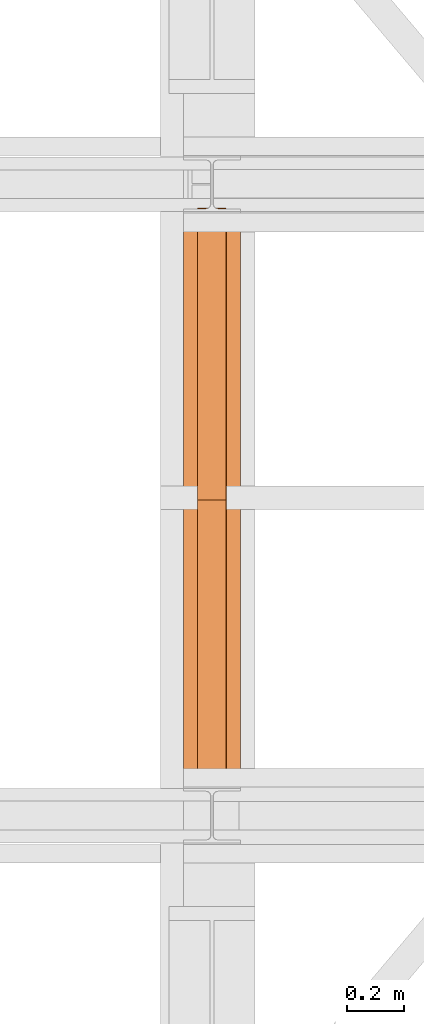
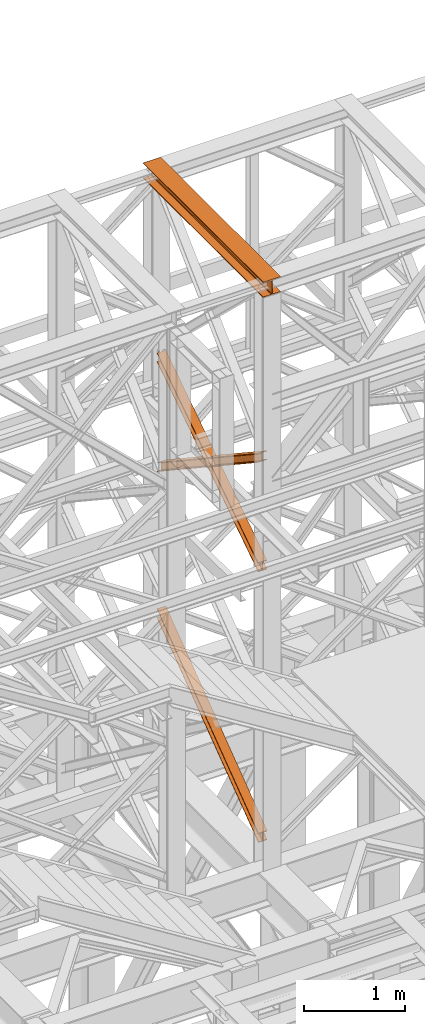
# One storey, part 115 of 208: 4 proxies.
"""IFC2X3 building model written with IfcOpenShell, lengths in millimetres."""

from ifc_helpers import new_model, entity, si_unit, converted_unit, frame, origin, origin_with_axes, place, context, subcontext, project, spatial, faceted_brep, element, save


model = new_model("IFC2X3")

# Units and contexts
model_context = context("Model", 3, precision=1e-05, world=origin())
plan_context = context("Plan", 3, precision=1e-05, world=origin())
body_context = subcontext(model_context, "Body", "Model", "MODEL_VIEW")
ifc_project = project(units=[si_unit("LENGTHUNIT", "METRE", prefix="MILLI"), converted_unit("PLANEANGLEUNIT", "DEGREE", entity("IfcPlaneAngleMeasure", 0.0174532925199433), si_unit("PLANEANGLEUNIT", "RADIAN"), dimensions=[0, 0, 0, 0, 0, 0, 0]), si_unit("AREAUNIT", "SQUARE_METRE"), si_unit("VOLUMEUNIT", "CUBIC_METRE")], contexts=[model_context, plan_context])

# Building, storey
building_placement = place(None, origin())
building = spatial("IfcBuilding", under=ifc_project, at=building_placement, CompositionType="COMPLEX")
storey_placement = place(building_placement, origin_with_axes())
storey = spatial("IfcBuildingStorey", under=building, at=storey_placement, Name="Geschoss", CompositionType="ELEMENT")

# Proxies
proxy_1_placement = place(storey_placement, frame((-106.745032961451, -16057.57439657637, 12249.99005869381), z_axis=(0.0, 0.0, 1.0), x_axis=(1.0, 0.0, 0.0)))
element("IfcBuildingElementProxy", 1, at=proxy_1_placement, inside=storey, context=body_context, shape_type="Brep", body=[
    faceted_brep([(0.01000000000000512, 2390.010012516976, 0.01000000000021828), (200.0100029802322, 2390.010012516976, 0.01000000000021828), (200.0100029802322, 2390.010012516976, 10.00999791383765), (121.2600035762787, 2390.010012516976, 10.01000536441825), (111.9441915473342, 2390.010012516976, 11.87455041170142), (105.1245498640835, 2390.010012516976, 18.69419349193595), (103.2600015571714, 2390.010012516976, 28.01000458955787), (103.2600015571714, 2390.010012516976, 162.0100153779986), (105.1245498640835, 2390.010012516976, 171.3258264756205), (111.9441915473342, 2390.010012516976, 178.145469555855), (121.2600035762787, 2390.010012516976, 180.0100146031382), (200.0100029802322, 2390.010012516976, 180.0100146031382), (200.0100029802322, 2390.010012516976, 190.0100125169756), (0.01000000000000512, 2390.010012516976, 190.0100125169756), (0.01000000000000512, 2390.010012516976, 180.0100146031382), (78.75999940395356, 2390.010012516976, 180.0100146031382), (88.07581143289805, 2390.010012516976, 178.145469555855), (94.89545311614872, 2390.010012516976, 171.3258264756205), (96.7600014230609, 2390.010012516976, 162.0100153779986), (96.7600014230609, 2390.010012516976, 28.01000458955787), (94.89545311614872, 2390.010012516976, 18.69419349193595), (88.07581143289805, 2390.010012516976, 11.87455041170142), (78.75999940395356, 2390.010012516976, 10.01000536441825), (0.01000000000000512, 2390.010012516976, 10.00999791383765), (200.0100029802322, 2390.010012516976, 0.01000000000021828), (0.01000000000000512, 2390.010012516976, 0.01000000000021828), (0.01000000000182411, 0.00999999999839929, 0.01000000000021828), (200.0100029802341, 0.00999999999839929, 0.01000000000021828), (200.0100029802322, 2390.010012516976, 10.00999791383765), (200.0100029802322, 2390.010012516976, 0.01000000000021828), (200.0100029802341, 0.00999999999839929, 0.01000000000021828), (200.0100029802341, 0.00999999999839929, 10.00999791383765), (121.2600035762787, 2390.010012516976, 10.01000536441825), (200.0100029802322, 2390.010012516976, 10.00999791383765), (200.0100029802341, 0.00999999999839929, 10.00999791383765), (121.2600035762805, 0.00999999999839929, 10.01000536441825), (111.9441915473342, 2390.010012516976, 11.87455041170142), (121.2600035762787, 2390.010012516976, 10.01000536441825), (121.2600035762805, 0.00999999999839929, 10.01000536441825), (111.944191547336, 0.00999999999839929, 11.87455041170142), (105.1245498640835, 2390.010012516976, 18.69419349193595), (111.9441915473342, 2390.010012516976, 11.87455041170142), (111.944191547336, 0.00999999999839929, 11.87455041170142), (105.1245498640854, 0.00999999999839929, 18.69419349193595), (103.2600015571714, 2390.010012516976, 28.01000458955787), (105.1245498640835, 2390.010012516976, 18.69419349193595), (105.1245498640854, 0.00999999999839929, 18.69419349193595), (103.2600015571732, 0.00999999999839929, 28.01000458955787), (103.2600015571714, 2390.010012516976, 162.0100153779986), (103.2600015571714, 2390.010012516976, 28.01000458955787), (103.2600015571732, 0.00999999999839929, 28.01000458955787), (103.2600015571732, 0.00999999999839929, 162.0100153779986), (105.1245498640835, 2390.010012516976, 171.3258264756205), (103.2600015571714, 2390.010012516976, 162.0100153779986), (103.2600015571732, 0.00999999999839929, 162.0100153779986), (105.1245498640854, 0.00999999999839929, 171.3258264756205), (111.9441915473342, 2390.010012516976, 178.145469555855), (105.1245498640835, 2390.010012516976, 171.3258264756205), (105.1245498640854, 0.00999999999839929, 171.3258264756205), (111.944191547336, 0.00999999999839929, 178.145469555855), (121.2600035762787, 2390.010012516976, 180.0100146031382), (111.9441915473342, 2390.010012516976, 178.145469555855), (111.944191547336, 0.00999999999839929, 178.145469555855), (121.2600035762805, 0.00999999999839929, 180.0100146031382), (200.0100029802322, 2390.010012516976, 180.0100146031382), (121.2600035762787, 2390.010012516976, 180.0100146031382), (121.2600035762805, 0.00999999999839929, 180.0100146031382), (200.0100029802341, 0.00999999999839929, 180.0100146031382), (200.0100029802322, 2390.010012516976, 190.0100125169756), (200.0100029802322, 2390.010012516976, 180.0100146031382), (200.0100029802341, 0.00999999999839929, 180.0100146031382), (200.0100029802341, 0.00999999999839929, 190.0100125169756), (0.01000000000000512, 2390.010012516976, 190.0100125169756), (200.0100029802322, 2390.010012516976, 190.0100125169756), (200.0100029802341, 0.00999999999839929, 190.0100125169756), (0.01000000000182411, 0.00999999999839929, 190.0100125169756), (0.01000000000000512, 2390.010012516976, 180.0100146031382), (0.01000000000000512, 2390.010012516976, 190.0100125169756), (0.01000000000182411, 0.00999999999839929, 190.0100125169756), (0.01000000000182411, 0.00999999999839929, 180.0100146031382), (78.75999940395356, 2390.010012516976, 180.0100146031382), (0.01000000000000512, 2390.010012516976, 180.0100146031382), (0.01000000000182411, 0.00999999999839929, 180.0100146031382), (78.75999940395538, 0.00999999999839929, 180.0100146031382), (88.07581143289805, 2390.010012516976, 178.145469555855), (78.75999940395356, 2390.010012516976, 180.0100146031382), (78.75999940395538, 0.00999999999839929, 180.0100146031382), (88.07581143289987, 0.00999999999839929, 178.145469555855), (94.89545311614872, 2390.010012516976, 171.3258264756205), (88.07581143289805, 2390.010012516976, 178.145469555855), (88.07581143289987, 0.00999999999839929, 178.145469555855), (94.89545311615053, 0.00999999999839929, 171.3258264756205), (96.7600014230609, 2390.010012516976, 162.0100153779986), (94.89545311614872, 2390.010012516976, 171.3258264756205), (94.89545311615053, 0.00999999999839929, 171.3258264756205), (96.76000142306272, 0.00999999999839929, 162.0100153779986), (96.7600014230609, 2390.010012516976, 28.01000458955787), (96.7600014230609, 2390.010012516976, 162.0100153779986), (96.76000142306272, 0.00999999999839929, 162.0100153779986), (96.76000142306272, 0.00999999999839929, 28.01000458955787), (94.89545311614872, 2390.010012516976, 18.69419349193595), (96.7600014230609, 2390.010012516976, 28.01000458955787), (96.76000142306272, 0.00999999999839929, 28.01000458955787), (94.89545311615053, 0.00999999999839929, 18.69419349193595), (88.07581143289805, 2390.010012516976, 11.87455041170142), (94.89545311614872, 2390.010012516976, 18.69419349193595), (94.89545311615053, 0.00999999999839929, 18.69419349193595), (88.07581143289987, 0.00999999999839929, 11.87455041170142), (78.75999940395356, 2390.010012516976, 10.01000536441825), (88.07581143289805, 2390.010012516976, 11.87455041170142), (88.07581143289987, 0.00999999999839929, 11.87455041170142), (78.75999940395538, 0.00999999999839929, 10.01000536441825), (0.01000000000000512, 2390.010012516976, 10.00999791383765), (78.75999940395356, 2390.010012516976, 10.01000536441825), (78.75999940395538, 0.00999999999839929, 10.01000536441825), (0.01000000000182411, 0.00999999999839929, 10.00999791383765), (0.01000000000000512, 2390.010012516976, 0.01000000000021828), (0.01000000000000512, 2390.010012516976, 10.00999791383765), (0.01000000000182411, 0.00999999999839929, 10.00999791383765), (0.01000000000182411, 0.00999999999839929, 0.01000000000021828), (0.01000000000182411, 0.00999999999839929, 0.01000000000021828), (0.01000000000182411, 0.00999999999839929, 10.00999791383765), (78.75999940395538, 0.00999999999839929, 10.01000536441825), (88.07581143289987, 0.00999999999839929, 11.87455041170142), (94.89545311615053, 0.00999999999839929, 18.69419349193595), (96.76000142306272, 0.00999999999839929, 28.01000458955787), (96.76000142306272, 0.00999999999839929, 162.0100153779986), (94.89545311615053, 0.00999999999839929, 171.3258264756205), (88.07581143289987, 0.00999999999839929, 178.145469555855), (78.75999940395538, 0.00999999999839929, 180.0100146031382), (0.01000000000182411, 0.00999999999839929, 180.0100146031382), (0.01000000000182411, 0.00999999999839929, 190.0100125169756), (200.0100029802341, 0.00999999999839929, 190.0100125169756), (200.0100029802341, 0.00999999999839929, 180.0100146031382), (121.2600035762805, 0.00999999999839929, 180.0100146031382), (111.944191547336, 0.00999999999839929, 178.145469555855), (105.1245498640854, 0.00999999999839929, 171.3258264756205), (103.2600015571732, 0.00999999999839929, 162.0100153779986), (103.2600015571732, 0.00999999999839929, 28.01000458955787), (105.1245498640854, 0.00999999999839929, 18.69419349193595), (111.944191547336, 0.00999999999839929, 11.87455041170142), (121.2600035762805, 0.00999999999839929, 10.01000536441825), (200.0100029802341, 0.00999999999839929, 10.00999791383765), (200.0100029802341, 0.00999999999839929, 0.01000000000021828)], [[[0, 1, 2, 3, 4, 5, 6, 7, 8, 9, 10, 11, 12, 13, 14, 15, 16, 17, 18, 19, 20, 21, 22, 23]], [[24, 25, 26, 27]], [[28, 29, 30, 31]], [[32, 33, 34, 35]], [[36, 37, 38, 39]], [[40, 41, 42, 43]], [[44, 45, 46, 47]], [[48, 49, 50, 51]], [[52, 53, 54, 55]], [[56, 57, 58, 59]], [[60, 61, 62, 63]], [[64, 65, 66, 67]], [[68, 69, 70, 71]], [[72, 73, 74, 75]], [[76, 77, 78, 79]], [[80, 81, 82, 83]], [[84, 85, 86, 87]], [[88, 89, 90, 91]], [[92, 93, 94, 95]], [[96, 97, 98, 99]], [[100, 101, 102, 103]], [[104, 105, 106, 107]], [[108, 109, 110, 111]], [[112, 113, 114, 115]], [[116, 117, 118, 119]], [[120, 121, 122, 123, 124, 125, 126, 127, 128, 129, 130, 131, 132, 133, 134, 135, 136, 137, 138, 139, 140, 141, 142, 143]]], orient=[[False], [False], [False], [False], [False], [False], [False], [False], [False], [False], [False], [False], [False], [False], [False], [False], [False], [False], [False], [False], [False], [False], [False], [False], [False], [False]]),
])
proxy_2_placement = place(storey_placement, frame((-57.29171440990627, -15867.5743840594, 8785.68637815495), z_axis=(0.0, 0.0, 1.0), x_axis=(1.0, 0.0, 0.0)))
element("IfcBuildingElementProxy", 2, at=proxy_2_placement, inside=storey, context=body_context, shape_type="Brep", body=[
    faceted_brep([(100.0233329519012, 2010.009987483023, 1330.225167941017), (100.1729351296906, 0.00999999999839929, 0.02100513656660041), (100.1718996660054, 0.00999999999839929, 9.435622162609434), (100.022296860672, 2010.009987483023, 1339.639782821612), (0.02333355746828403, 2010.009987483023, 1330.214162804454), (0.1729357352558125, 0.00999999999839929, 0.01000000000021828), (100.1729351296906, 0.00999999999839929, 0.02100513656660041), (100.0233329519012, 2010.009987483023, 1330.225167941017), (0.02229746624085038, 2010.009987483023, 1339.628777685057), (0.1719002715706282, 0.00999999999839929, 9.424617026043052), (0.1729357352558125, 0.00999999999839929, 0.01000000000021828), (0.02333355746828403, 2010.009987483023, 1330.214162804454), (47.52229717859496, 2010.009987483023, 1339.634005124923), (47.67189998392656, 0.00999999999839929, 9.429844465905262), (0.1719002715706282, 0.00999999999839929, 9.424617026043052), (0.02229746624085038, 2010.009987483023, 1339.628777685057), (47.51193626628788, 2010.009987483023, 1433.780153930935), (47.66154536058981, 0.00999999999839929, 103.5760147725105), (47.67189998392656, 0.00999999999839929, 9.429844465905262), (47.52229717859496, 2010.009987483023, 1339.634005124923), (0.01106478197630878, 2021.979642245309, 1441.696427017001), (0.01120823570614249, 2020.00998539686, 1440.39291091142), (29.30668085241064, 2020.00998539686, 1440.396134918205), (38.62249288135514, 2021.874530444144, 1441.631113415808), (38.72760466098931, 2021.979642245309, 1441.70068782511), (47.51193626628788, 2010.009987483023, 1433.780153930935), (0.01193655393195314, 2010.009987483023, 1433.774926491073), (0.1615456482338757, 0.00999999999839929, 103.5707873326446), (47.66154536058981, 0.00999999999839929, 103.5760147725105), (0.00999999999999801, 2022.373573614999, 1451.371745118717), (0.01017214447507087, 2020.00998539686, 1449.807525792019), (0.01120823570614249, 2020.00998539686, 1440.39291091142), (0.01106478197630878, 2021.979642245309, 1441.696427017001), (0.01193655393195314, 2010.009987483023, 1433.774926491073), (0.01090046270270051, 2010.009987483023, 1443.189541371672), (0.1605101872535286, 0.00999999999839929, 112.9854043679352), (0.1615456482338757, 0.00999999999839929, 103.5707873326446), (100.0099993944384, 2022.373573614997, 1451.382750255283), (100.0101715389135, 2020.00998539686, 1449.818530928586), (71.80668502473577, 2020.00998539686, 1449.815427096359), (62.49087299579129, 2021.874530444144, 1451.048355158282), (61.99182992716465, 2022.373573614999, 1451.378566303787), (0.01090046270270051, 2010.009987483023, 1443.189541371672), (100.0108998571393, 2010.009987483023, 1443.200546508238), (100.1605095816919, 0.00999999999839929, 112.9964095044979), (0.1605101872535286, 0.00999999999839929, 112.9854043679352), (0.01017214447507087, 2020.00998539686, 1449.807525792019), (0.00999999999999801, 2022.373573614999, 1451.371745118717), (39.12153594997995, 2022.373573614999, 1451.376049396686), (38.62249288135514, 2021.874530444144, 1451.045728410436), (29.30668085241064, 2020.00998539686, 1449.810749912833), (100.0110641764129, 2021.979642245307, 1441.707432153557), (100.0112076301409, 2020.00998539686, 1440.403916047975), (100.0101715389135, 2020.00998539686, 1449.818530928586), (100.0099993944384, 2022.373573614997, 1451.382750255283), (100.0108998571393, 2010.009987483023, 1443.200546508238), (100.0119359483704, 2010.009987483023, 1433.785931627628), (100.1615450426668, 0.00999999999839929, 103.5817924692037), (100.1605095816919, 0.00999999999839929, 112.9964095044979), (52.5119362360108, 2010.009987483023, 1433.780704187766), (52.66154533031273, 0.00999999999839929, 103.5765650293379), (100.1615450426668, 0.00999999999839929, 103.5817924692037), (100.0119359483704, 2010.009987483023, 1433.785931627628), (71.80668502473577, 2020.00998539686, 1440.400812101727), (100.0112076301409, 2020.00998539686, 1440.403916047975), (100.0110641764129, 2021.979642245307, 1441.707432153557), (62.38576121615711, 2021.979642245309, 1441.703291437565), (62.49087299579129, 2021.874530444144, 1441.63374016365), (52.52229714831424, 2010.009987483023, 1339.63455538175), (52.67189995364766, 0.00999999999839929, 9.43039472273631), (52.66154533031273, 0.00999999999839929, 103.5765650293379), (52.5119362360108, 2010.009987483023, 1433.780704187766), (100.022296860672, 2010.009987483023, 1339.639782821612), (100.1718996660054, 0.00999999999839929, 9.435622162609434), (52.67189995364766, 0.00999999999839929, 9.43039472273631), (52.52229714831424, 2010.009987483023, 1339.63455538175), (62.38576121615711, 2021.979642245309, 1441.703291437565), (100.0110641764129, 2021.979642245307, 1441.707432153557), (100.0099993944384, 2022.373573614997, 1451.382750255283), (61.99182992716465, 2022.373573614999, 1451.378566303787), (39.12153594997995, 2022.373573614999, 1451.376049396686), (0.00999999999999801, 2022.373573614999, 1451.371745118717), (0.01106478197630878, 2021.979642245309, 1441.696427017001), (38.72760466098931, 2021.979642245309, 1441.70068782511), (62.49087299579129, 2021.874530444144, 1441.63374016365), (62.38576121615711, 2021.979642245309, 1441.703291437565), (61.99182992716465, 2022.373573614999, 1451.378566303787), (62.49087299579129, 2021.874530444144, 1451.048355158282), (62.49087299579129, 2021.874530444144, 1451.048355158282), (71.80668502473577, 2020.00998539686, 1449.815427096359), (71.80668502473577, 2020.00998539686, 1440.400812101727), (62.49087299579129, 2021.874530444144, 1441.63374016365), (71.80668502473577, 2020.00998539686, 1449.815427096359), (100.0101715389135, 2020.00998539686, 1449.818530928586), (100.0112076301409, 2020.00998539686, 1440.403916047975), (71.80668502473577, 2020.00998539686, 1440.400812101727), (100.022296860672, 2010.009987483023, 1339.639782821612), (52.52229714831424, 2010.009987483023, 1339.63455538175), (52.5119362360108, 2010.009987483023, 1433.780704187766), (100.0119359483704, 2010.009987483023, 1433.785931627628), (100.0108998571393, 2010.009987483023, 1443.200546508238), (0.01090046270270051, 2010.009987483023, 1443.189541371672), (0.01193655393195314, 2010.009987483023, 1433.774926491073), (47.51193626628788, 2010.009987483023, 1433.780153930935), (47.52229717859496, 2010.009987483023, 1339.634005124923), (0.02229746624085038, 2010.009987483023, 1339.628777685057), (0.02333355746828403, 2010.009987483023, 1330.214162804454), (100.0233329519012, 2010.009987483023, 1330.225167941017), (29.30668085241064, 2020.00998539686, 1440.396134918205), (0.01120823570614249, 2020.00998539686, 1440.39291091142), (0.01017214447507087, 2020.00998539686, 1449.807525792019), (29.30668085241064, 2020.00998539686, 1449.810749912833), (29.30668085241064, 2020.00998539686, 1449.810749912833), (38.62249288135514, 2021.874530444144, 1451.045728410436), (38.62249288135514, 2021.874530444144, 1441.631113415808), (29.30668085241064, 2020.00998539686, 1440.396134918205), (38.62249288135514, 2021.874530444144, 1451.045728410436), (39.12153594997995, 2022.373573614999, 1451.376049396686), (38.72760466098931, 2021.979642245309, 1441.70068782511), (38.62249288135514, 2021.874530444144, 1441.631113415808), (100.1729351296906, 0.00999999999839929, 0.02100513656660041), (0.1729357352558125, 0.00999999999839929, 0.01000000000021828), (0.1719002715706282, 0.00999999999839929, 9.424617026043052), (47.67189998392656, 0.00999999999839929, 9.429844465905262), (47.66154536058981, 0.00999999999839929, 103.5760147725105), (0.1615456482338757, 0.00999999999839929, 103.5707873326446), (0.1605101872535286, 0.00999999999839929, 112.9854043679352), (100.1605095816919, 0.00999999999839929, 112.9964095044979), (100.1615450426668, 0.00999999999839929, 103.5817924692037), (52.66154533031273, 0.00999999999839929, 103.5765650293379), (52.67189995364766, 0.00999999999839929, 9.43039472273631), (100.1718996660054, 0.00999999999839929, 9.435622162609434)], [[[0, 1, 2, 3]], [[4, 5, 6, 7]], [[8, 9, 10, 11]], [[12, 13, 14, 15]], [[16, 17, 18, 19]], [[20, 21, 22, 23, 24]], [[25, 26, 27, 28]], [[29, 30, 31, 32]], [[33, 34, 35, 36]], [[37, 38, 39, 40, 41]], [[42, 43, 44, 45]], [[46, 47, 48, 49, 50]], [[51, 52, 53, 54]], [[55, 56, 57, 58]], [[59, 60, 61, 62]], [[63, 64, 65, 66, 67]], [[68, 69, 70, 71]], [[72, 73, 74, 75]], [[76, 77, 78, 79]], [[80, 81, 82, 83]], [[84, 85, 86, 87]], [[88, 89, 90, 91]], [[92, 93, 94, 95]], [[96, 97, 98, 99, 100, 101, 102, 103, 104, 105, 106, 107]], [[108, 109, 110, 111]], [[112, 113, 114, 115]], [[116, 117, 118, 119]], [[120, 121, 122, 123, 124, 125, 126, 127, 128, 129, 130, 131]]], orient=[[False], [False], [False], [False], [False], [False], [False], [False], [False], [False], [False], [False], [False], [False], [False], [False], [False], [False], [False], [False], [False], [False], [False], [False], [False], [False], [False], [False]]),
])
proxy_3_placement = place(storey_placement, frame((-57.282239092159, -15867.5743840594, 8785.050753356181), z_axis=(0.0, 0.0, 1.0), x_axis=(1.0, 0.0, 0.0)))
element("IfcBuildingElementProxy", 3, at=proxy_3_placement, inside=storey, context=body_context, shape_type="Brep", body=[
    faceted_brep([(100.0213960296203, 0.01000000000021828, 1340.168495796863), (100.1712583843325, 2010.009987483025, 9.436734304987112), (100.172293937763, 2010.009987483025, 0.02100513655932446), (100.0224320873656, 0.01000000000021828, 1330.752768748162), (100.0224320873656, 0.01000000000021828, 1330.752768748162), (100.172293937763, 2010.009987483025, 0.02100513655932446), (0.1722945433282419, 2010.009987483025, 0.01000000000021828), (0.02243269293263239, 0.01000000000021828, 1330.741763611606), (0.02243269293263239, 0.01000000000021828, 1330.741763611606), (0.1722945433282419, 2010.009987483025, 0.01000000000021828), (0.1712589898995773, 2010.009987483025, 9.425729168431644), (0.02139663518915569, 0.01000000000021828, 1340.1574906603), (0.02139663518915569, 0.01000000000021828, 1340.1574906603), (0.1712589898995773, 2010.009987483025, 9.425729168431644), (47.67125870225733, 2010.009987483025, 9.430956608297492), (47.5213963475469, 0.01000000000021828, 1340.162718100166), (47.5213963475469, 0.01000000000021828, 1340.162718100166), (47.67125870225733, 2010.009987483025, 9.430956608297492), (47.66090317872455, 2010.009987483025, 103.5882483377918), (47.51103577010122, 0.01000000000021828, 1434.319988587145), (47.51103577010122, 0.01000000000021828, 1434.319988587145), (47.66090317872455, 2010.009987483025, 103.5882483377918), (0.160903466368616, 2010.009987483025, 103.583020897926), (0.0110360577452937, 0.01000000000021828, 1434.31476114728), (0.0110360577452937, 0.01000000000021828, 1434.31476114728), (0.160903466368616, 2010.009987483025, 103.583020897926), (0.1598679150918159, 2010.009987483025, 112.998750075405), (0.00999999999999801, 0.01000000000021828, 1443.730488195981), (0.00999999999999801, 0.01000000000021828, 1443.730488195981), (0.1598679150918159, 2010.009987483025, 112.998750075405), (100.1598673095248, 2010.009987483025, 113.0097552119678), (100.0099993944348, 0.01000000000021828, 1443.741493332544), (100.0099993944348, 0.01000000000021828, 1443.741493332544), (100.1598673095248, 2010.009987483025, 113.0097552119678), (100.1609028608016, 2010.009987483025, 103.5940260344851), (100.0110354521783, 0.01000000000021828, 1434.325766283846), (100.0110354521783, 0.01000000000021828, 1434.325766283846), (100.1609028608016, 2010.009987483025, 103.5940260344851), (52.66090314844565, 2010.009987483025, 103.5887985946229), (52.51103573982415, 0.01000000000021828, 1434.320538843973), (52.51103573982415, 0.01000000000021828, 1434.320538843973), (52.66090314844565, 2010.009987483025, 103.5887985946229), (52.67125867197661, 2010.009987483025, 9.431506865121264), (52.52139631726801, 0.01000000000021828, 1340.163268357001), (52.52139631726801, 0.01000000000021828, 1340.163268357001), (52.67125867197661, 2010.009987483025, 9.431506865121264), (100.1712583843325, 2010.009987483025, 9.436734304987112), (100.0213960296203, 0.01000000000021828, 1340.168495796863), (100.0224320873656, 0.01000000000021828, 1330.752768748162), (0.02243269293263239, 0.01000000000021828, 1330.741763611606), (0.02139663518915569, 0.01000000000021828, 1340.1574906603), (47.5213963475469, 0.01000000000021828, 1340.162718100166), (47.51103577010122, 0.01000000000021828, 1434.319988587145), (0.0110360577452937, 0.01000000000021828, 1434.31476114728), (0.00999999999999801, 0.01000000000021828, 1443.730488195981), (100.0099993944348, 0.01000000000021828, 1443.741493332544), (100.0110354521783, 0.01000000000021828, 1434.325766283846), (52.51103573982415, 0.01000000000021828, 1434.320538843973), (52.52139631726801, 0.01000000000021828, 1340.163268357001), (100.0213960296203, 0.01000000000021828, 1340.168495796863), (100.1712583843325, 2010.009987483025, 9.436734304987112), (52.67125867197661, 2010.009987483025, 9.431506865121264), (52.66090314844565, 2010.009987483025, 103.5887985946229), (100.1609028608016, 2010.009987483025, 103.5940260344851), (100.1598673095248, 2010.009987483025, 113.0097552119678), (0.1598679150918159, 2010.009987483025, 112.998750075405), (0.160903466368616, 2010.009987483025, 103.583020897926), (47.66090317872455, 2010.009987483025, 103.5882483377918), (47.67125870225733, 2010.009987483025, 9.430956608297492), (0.1712589898995773, 2010.009987483025, 9.425729168431644), (0.1722945433282419, 2010.009987483025, 0.01000000000021828), (100.172293937763, 2010.009987483025, 0.02100513655932446)], [[[0, 1, 2, 3]], [[4, 5, 6, 7]], [[8, 9, 10, 11]], [[12, 13, 14, 15]], [[16, 17, 18, 19]], [[20, 21, 22, 23]], [[24, 25, 26, 27]], [[28, 29, 30, 31]], [[32, 33, 34, 35]], [[36, 37, 38, 39]], [[40, 41, 42, 43]], [[44, 45, 46, 47]], [[48, 49, 50, 51, 52, 53, 54, 55, 56, 57, 58, 59]], [[60, 61, 62, 63, 64, 65, 66, 67, 68, 69, 70, 71]]], orient=[[False], [False], [False], [False], [False], [False], [False], [False], [False], [False], [False], [False], [False], [False]]),
])
proxy_4_placement = place(storey_placement, frame((-56.91720150889683, -15873.1965123697, 5499.689768811883), z_axis=(0.0, 0.0, 1.0), x_axis=(1.0, 0.0, 0.0)))
element("IfcBuildingElementProxy", 4, at=proxy_4_placement, inside=storey, context=body_context, shape_type="Brep", body=[
    faceted_brep([(100.0229428112286, 2015.632115793322, 1505.703241650141), (100.1858455764684, 1.953628280809426, 0.02100513656296243), (100.1847800613884, 1.791659257409265, 9.702984703128095), (100.021864193164, 2015.632115793322, 1515.50632986583), (0.02294341679749579, 2015.632115793322, 1505.692236513578), (0.1858461820336359, 1.953628280809426, 0.01000000000021828), (100.1858455764684, 1.953628280809426, 0.02100513656296243), (100.0229428112286, 2015.632115793322, 1505.703241650141), (0.02186479873103764, 2015.632115793322, 1515.495324729271), (0.1847806669536638, 1.791659257407446, 9.691979566568989), (0.1858461820336359, 1.953628280809426, 0.01000000000021828), (0.02294341679749579, 2015.632115793322, 1505.692236513578), (47.52186451108333, 2015.632115793322, 1515.500552169136), (47.68478037930959, 1.791659257407446, 9.697207006434837), (0.1847806669536638, 1.791659257407446, 9.691979566568989), (0.02186479873103764, 2015.632115793322, 1515.495324729271), (47.51107833042602, 2015.632115793322, 1613.531434326045), (47.67412522851715, 0.1719690234003792, 106.517002672068), (47.68478037930959, 1.791659257407446, 9.697207006434837), (47.52186451108333, 2015.632115793322, 1515.500552169136), (0.01107861806827515, 2015.632115793322, 1613.526206886179), (0.1741255161575808, 0.1719690234003792, 106.5117752322021), (47.67412522851715, 0.1719690234003792, 106.517002672068), (47.51107833042602, 2015.632115793322, 1613.531434326045), (0.00999999999999801, 2015.632115793322, 1623.329295101868), (0.1730600010776087, 0.01000000000021828, 116.1937547987636), (0.1741255161575808, 0.1719690234003792, 106.5117752322021), (0.01107861806827515, 2015.632115793322, 1613.526206886179), (100.0099993944384, 2015.632115793322, 1623.340300238435), (100.1730593955124, 0.01000000000203727, 116.2047599353264), (0.1730600010776087, 0.01000000000021828, 116.1937547987636), (0.00999999999999801, 2015.632115793322, 1623.329295101868), (100.0110780125049, 2015.632115793322, 1613.537212022739), (100.1741249105905, 0.1719690234003792, 106.5227803687612), (100.1730593955124, 0.01000000000203727, 116.2047599353264), (100.0099993944384, 2015.632115793322, 1623.340300238435), (52.51107830014895, 2015.632115793322, 1613.531984582873), (52.67412519823643, 0.1719690234003792, 106.5175529288954), (100.1741249105905, 0.1719690234003792, 106.5227803687612), (100.0110780125049, 2015.632115793322, 1613.537212022739), (52.52186448080807, 2015.632115793322, 1515.501102425964), (52.68478034903252, 1.791659257409265, 9.697757263262247), (52.67412519823643, 0.1719690234003792, 106.5175529288954), (52.51107830014895, 2015.632115793322, 1613.531984582873), (100.021864193164, 2015.632115793322, 1515.50632986583), (100.1847800613884, 1.791659257409265, 9.702984703128095), (52.68478034903252, 1.791659257409265, 9.697757263262247), (52.52186448080807, 2015.632115793322, 1515.501102425964), (100.1858455764684, 1.953628280809426, 0.02100513656296243), (0.1858461820336359, 1.953628280809426, 0.01000000000021828), (0.1847806669536638, 1.791659257407446, 9.691979566568989), (47.68478037930959, 1.791659257407446, 9.697207006434837), (47.67412522851715, 0.1719690234003792, 106.517002672068), (0.1741255161575808, 0.1719690234003792, 106.5117752322021), (0.1730600010776087, 0.01000000000021828, 116.1937547987636), (100.1730593955124, 0.01000000000203727, 116.2047599353264), (100.1741249105905, 0.1719690234003792, 106.5227803687612), (52.67412519823643, 0.1719690234003792, 106.5175529288954), (52.68478034903252, 1.791659257409265, 9.697757263262247), (100.1847800613884, 1.791659257409265, 9.702984703128095), (100.021864193164, 2015.632115793322, 1515.50632986583), (52.52186448080807, 2015.632115793322, 1515.501102425964), (52.51107830014895, 2015.632115793322, 1613.531984582873), (100.0110780125049, 2015.632115793322, 1613.537212022739), (100.0099993944384, 2015.632115793322, 1623.340300238435), (0.00999999999999801, 2015.632115793322, 1623.329295101868), (0.01107861806827515, 2015.632115793322, 1613.526206886179), (47.51107833042602, 2015.632115793322, 1613.531434326045), (47.52186451108333, 2015.632115793322, 1515.500552169136), (0.02186479873103764, 2015.632115793322, 1515.495324729271), (0.02294341679749579, 2015.632115793322, 1505.692236513578), (100.0229428112286, 2015.632115793322, 1505.703241650141)], [[[0, 1, 2, 3]], [[4, 5, 6, 7]], [[8, 9, 10, 11]], [[12, 13, 14, 15]], [[16, 17, 18, 19]], [[20, 21, 22, 23]], [[24, 25, 26, 27]], [[28, 29, 30, 31]], [[32, 33, 34, 35]], [[36, 37, 38, 39]], [[40, 41, 42, 43]], [[44, 45, 46, 47]], [[48, 49, 50, 51, 52, 53, 54, 55, 56, 57, 58, 59]], [[60, 61, 62, 63, 64, 65, 66, 67, 68, 69, 70, 71]]], orient=[[False], [False], [False], [False], [False], [False], [False], [False], [False], [False], [False], [False], [False], [False]]),
])

save(model, "model.ifc")
